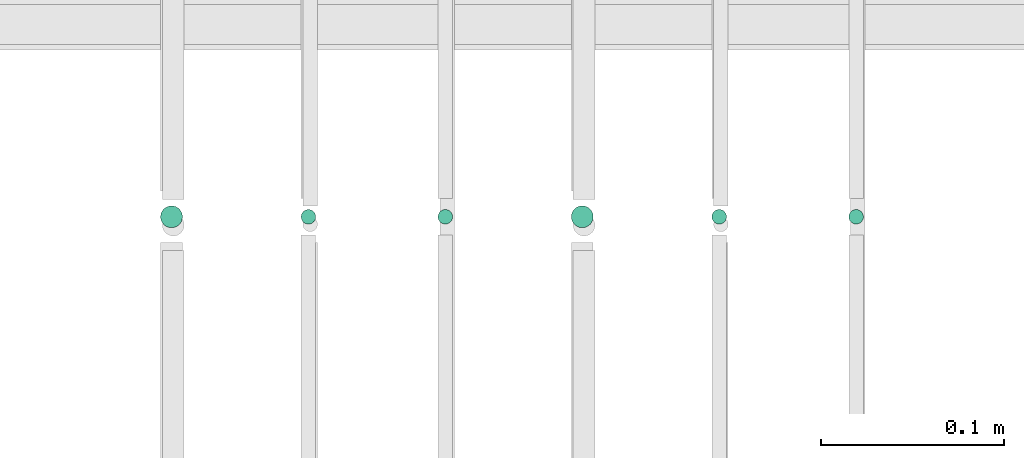
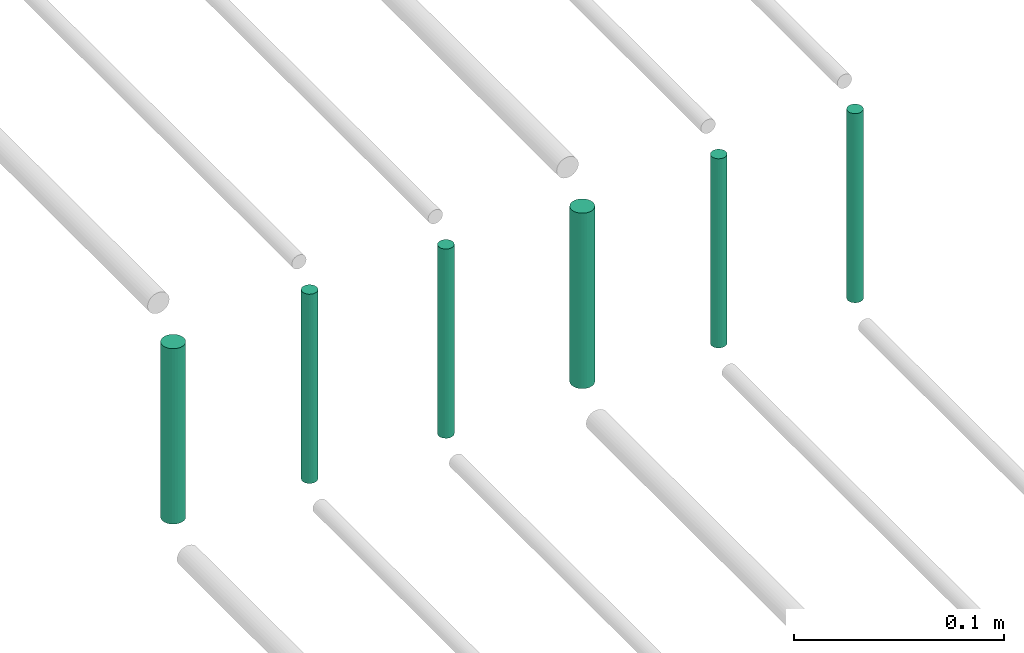
# One storey, part 201 of 331: 6 flow segments.
"""IFC2X3 building model written with IfcOpenShell, lengths in millimetres."""

from ifc_helpers import new_model, entity, si_unit, converted_unit, derived_unit, direction, frame, frame_2d, origin, origin_2d_with_axis, place, context, subcontext, project, spatial, circle, extrude, type_object, element, save


model = new_model("IFC2X3")

# Units and contexts
model_context = context("Model", 3, precision=0.01, world=origin(), true_north=direction((6.12303176911189e-17, 1.0)))
body_context = subcontext(model_context, "Body", "Model", "MODEL_VIEW")
ifc_project = project(units=[si_unit("LENGTHUNIT", "METRE", prefix="MILLI"), si_unit("AREAUNIT", "SQUARE_METRE"), si_unit("VOLUMEUNIT", "CUBIC_METRE"), converted_unit("PLANEANGLEUNIT", "DEGREE", entity("IfcRatioMeasure", 0.0174532925199433), si_unit("PLANEANGLEUNIT", "RADIAN"), dimensions=[0, 0, 0, 0, 0, 0, 0]), si_unit("MASSUNIT", "GRAM", prefix="KILO"), derived_unit("MASSDENSITYUNIT", [(si_unit("MASSUNIT", "GRAM", prefix="KILO"), 1), (si_unit("LENGTHUNIT", "METRE"), -3)]), derived_unit("MOMENTOFINERTIAUNIT", [(si_unit("LENGTHUNIT", "METRE"), 4)]), si_unit("TIMEUNIT", "SECOND"), si_unit("FREQUENCYUNIT", "HERTZ"), si_unit("THERMODYNAMICTEMPERATUREUNIT", "DEGREE_CELSIUS"), derived_unit("THERMALTRANSMITTANCEUNIT", [(si_unit("MASSUNIT", "GRAM", prefix="KILO"), 1), (si_unit("THERMODYNAMICTEMPERATUREUNIT", "KELVIN"), -1), (si_unit("TIMEUNIT", "SECOND"), -3)]), derived_unit("VOLUMETRICFLOWRATEUNIT", [(si_unit("LENGTHUNIT", "METRE"), 3), (si_unit("TIMEUNIT", "SECOND"), -1)]), derived_unit("MASSFLOWRATEUNIT", [(si_unit("MASSUNIT", "GRAM", prefix="KILO"), 1), (si_unit("TIMEUNIT", "SECOND"), -1)]), derived_unit("ROTATIONALFREQUENCYUNIT", [(si_unit("TIMEUNIT", "SECOND"), -1)]), si_unit("ELECTRICCURRENTUNIT", "AMPERE"), si_unit("ELECTRICVOLTAGEUNIT", "VOLT"), si_unit("POWERUNIT", "WATT"), si_unit("FORCEUNIT", "NEWTON", prefix="KILO"), si_unit("ILLUMINANCEUNIT", "LUX"), si_unit("LUMINOUSFLUXUNIT", "LUMEN"), si_unit("LUMINOUSINTENSITYUNIT", "CANDELA"), derived_unit("USERDEFINED", [(si_unit("MASSUNIT", "GRAM", prefix="KILO"), -1), (si_unit("LENGTHUNIT", "METRE"), -2), (si_unit("TIMEUNIT", "SECOND"), 3), (si_unit("LUMINOUSFLUXUNIT", "LUMEN"), 1)]), derived_unit("LINEARVELOCITYUNIT", [(si_unit("LENGTHUNIT", "METRE"), 1), (si_unit("TIMEUNIT", "SECOND"), -1)]), si_unit("PRESSUREUNIT", "PASCAL"), derived_unit("USERDEFINED", [(si_unit("LENGTHUNIT", "METRE"), -2), (si_unit("MASSUNIT", "GRAM", prefix="KILO"), 1), (si_unit("TIMEUNIT", "SECOND"), -2)]), derived_unit("LINEARFORCEUNIT", [(si_unit("MASSUNIT", "GRAM", prefix="KILO"), 1), (si_unit("LENGTHUNIT", "METRE"), 1), (si_unit("TIMEUNIT", "SECOND"), -2), (si_unit("LENGTHUNIT", "METRE"), -1)]), derived_unit("PLANARFORCEUNIT", [(si_unit("MASSUNIT", "GRAM", prefix="KILO"), 1), (si_unit("LENGTHUNIT", "METRE"), 1), (si_unit("TIMEUNIT", "SECOND"), -2), (si_unit("LENGTHUNIT", "METRE"), -2)])], contexts=[model_context])

# Site, building, storey
site_placement = place(None, frame((0.0, -0.00077364408347762, 0.0)))
site = spatial("IfcSite", under=ifc_project, at=site_placement, CompositionType="ELEMENT")
building_placement = place(site_placement, origin())
building = spatial("IfcBuilding", under=site, at=building_placement, CompositionType="ELEMENT")
storey_placement = place(building_placement, origin())
storey = spatial("IfcBuildingStorey", under=building, at=storey_placement, CompositionType="ELEMENT", Elevation=0.0)

# Flow segments
pipe_segment_type = type_object("IfcPipeSegmentType", PredefinedType="NOTDEFINED")
flow_segment_1_placement = place(storey_placement, frame((54064.5706481368, 8084.55353441893, 18460.0)))
element("IfcFlowSegment", 1, at=flow_segment_1_placement, inside=storey, type_object=pipe_segment_type, context=body_context, shape_type="SweptSolid", body=[
    extrude(circle(Radius=4.0, at=frame_2d((0.0, 1.08286712929839e-12), x_axis=(1.0, 0.0))), frame((5.59527223591499, 5.59527223591716, 0.0), z_axis=(0.0, 0.0, 1.0), x_axis=(-1.0, 0.0, 0.0)), (0.0, 0.0, 1.0), 110.000000000014),
])
flow_segment_2_placement = place(storey_placement, frame((53989.5706481368, 8084.55353441892, 18460.0)))
element("IfcFlowSegment", 2, at=flow_segment_2_placement, inside=storey, type_object=pipe_segment_type, context=body_context, shape_type="SweptSolid", body=[
    extrude(circle(Radius=4.0, at=frame_2d((0.0, -1.08286712929839e-12), x_axis=(1.0, 0.0))), frame((5.59527223591499, 5.59527223591716, 0.0)), (0.0, 0.0, 1.0), 110.00000000001),
])
flow_segment_3_placement = place(storey_placement, frame((53912.5706481368, 8082.55353441901, 18464.0)))
element("IfcFlowSegment", 3, at=flow_segment_3_placement, inside=storey, type_object=pipe_segment_type, context=body_context, shape_type="SweptSolid", body=[
    extrude(circle(Radius=6.0, at=origin_2d_with_axis()), frame((7.59527223591454, 7.59527223591562, 0.0), z_axis=(0.0, 0.0, 1.0), x_axis=(-1.0, 0.0, 0.0)), (0.0, 0.0, 1.0), 102.000000000014),
])
flow_segment_4_placement = place(storey_placement, frame((53839.5706481368, 8084.55353441901, 18460.0)))
element("IfcFlowSegment", 4, at=flow_segment_4_placement, inside=storey, type_object=pipe_segment_type, context=body_context, shape_type="SweptSolid", body=[
    extrude(circle(Radius=4.0, at=origin_2d_with_axis()), frame((5.59527223591499, 5.59527223591607, 0.0), z_axis=(0.0, 0.0, 1.0), x_axis=(-1.0, 0.0, 0.0)), (0.0, 0.0, 1.0), 110.000000000053),
])
flow_segment_5_placement = place(storey_placement, frame((53764.5706481368, 8084.55353441901, 18460.0)))
element("IfcFlowSegment", 5, at=flow_segment_5_placement, inside=storey, type_object=pipe_segment_type, context=body_context, shape_type="SweptSolid", body=[
    extrude(circle(Radius=4.0, at=origin_2d_with_axis()), frame((5.59527223591499, 5.59527223591607, 0.0), z_axis=(0.0, 0.0, 1.0), x_axis=(-1.0, 0.0, 0.0)), (0.0, 0.0, 1.0), 110.000000000036),
])
flow_segment_6_placement = place(storey_placement, frame((53687.5706481368, 8082.55353441901, 18464.0)))
element("IfcFlowSegment", 6, at=flow_segment_6_placement, inside=storey, type_object=pipe_segment_type, context=body_context, shape_type="SweptSolid", body=[
    extrude(circle(Radius=6.0, at=origin_2d_with_axis()), frame((7.59527223591454, 7.59527223591562, 0.0), z_axis=(0.0, 0.0, 1.0), x_axis=(-1.0, 0.0, 0.0)), (0.0, 0.0, 1.0), 102.000000000055),
])

save(model, "model.ifc")
